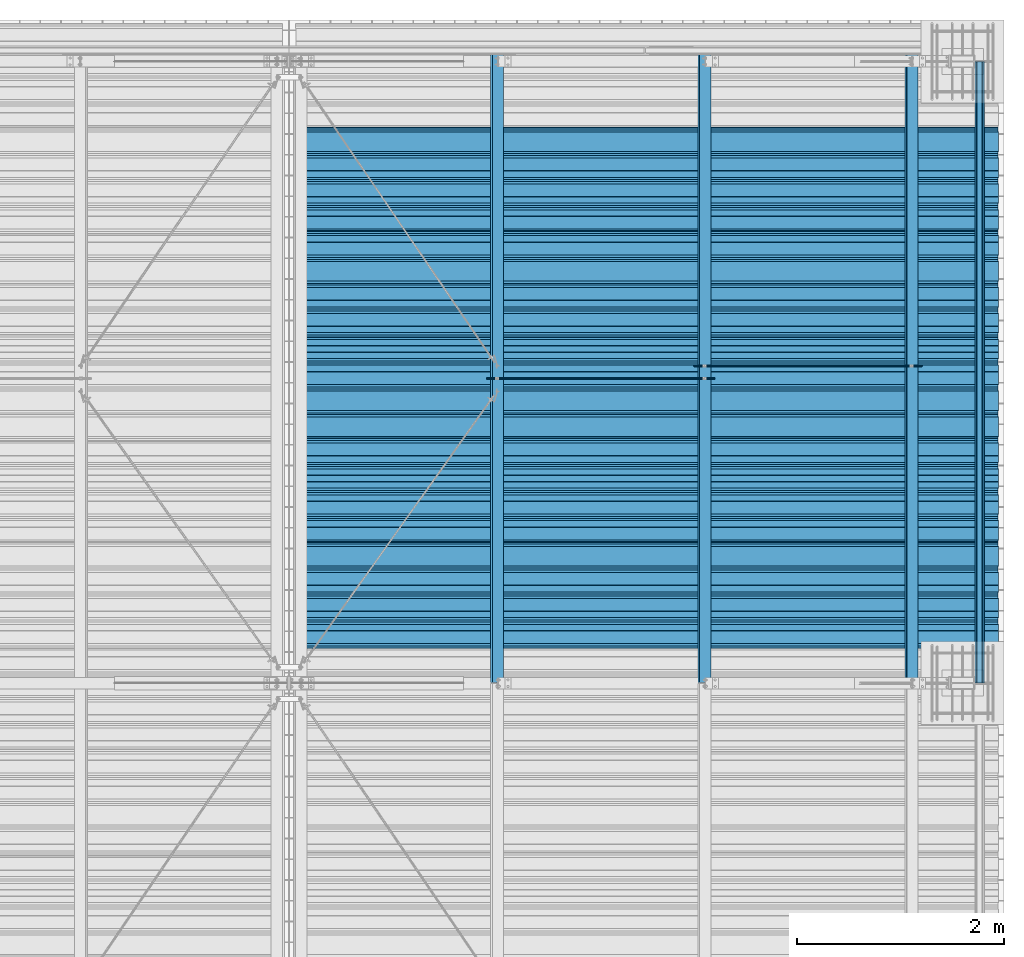
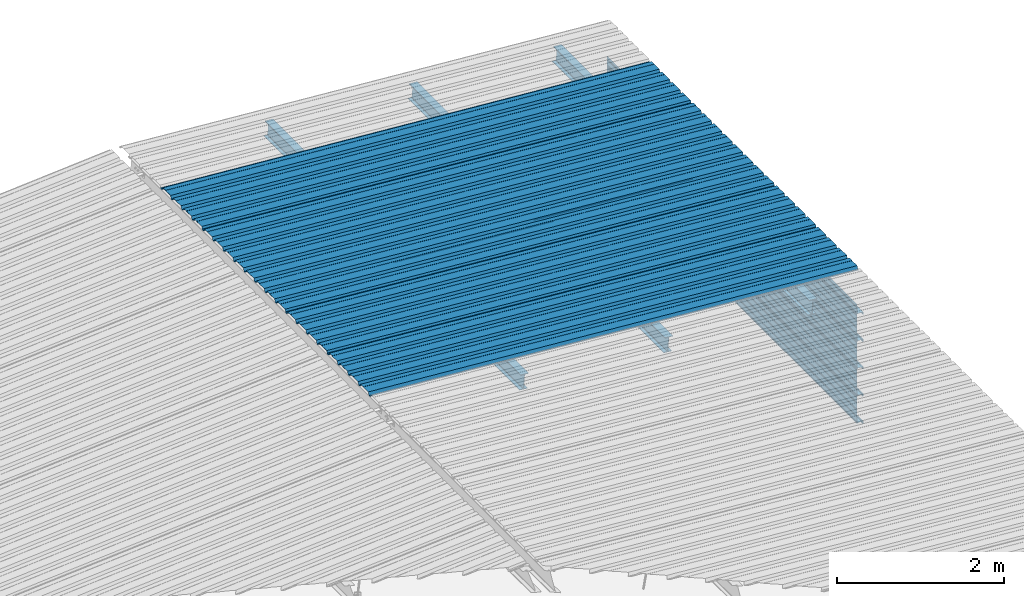
# One storey, part 18 of 70: 15 beams, 15 elements without a shape of their own.
"""IFC2X3 building model written with IfcOpenShell, lengths in millimetres."""

from ifc_helpers import new_model, si_unit, frame, origin_with_axes, origin_2d_with_axis, place, context, subcontext, project, spatial, polyline, circle, i_section, outline, extrude, clip, halfspace, material, type_object, element, aggregate, save


model = new_model("IFC2X3")

# Units and contexts
model_context = context("Model", 3, precision=1e-05, world=origin_with_axes())
body_context = subcontext(model_context, "Body", "Model", "MODEL_VIEW")
ifc_project = project(units=[si_unit("LENGTHUNIT", "METRE", prefix="MILLI"), si_unit("AREAUNIT", "SQUARE_METRE"), si_unit("VOLUMEUNIT", "CUBIC_METRE"), si_unit("MASSUNIT", "GRAM", prefix="KILO"), si_unit("TIMEUNIT", "SECOND"), si_unit("PLANEANGLEUNIT", "RADIAN"), si_unit("SOLIDANGLEUNIT", "STERADIAN"), si_unit("THERMODYNAMICTEMPERATUREUNIT", "DEGREE_CELSIUS"), si_unit("LUMINOUSINTENSITYUNIT", "LUMEN")], contexts=[model_context])

# Site, building, storey
site_placement = place(None, origin_with_axes())
site = spatial("IfcSite", under=ifc_project, at=site_placement, CompositionType="ELEMENT")
building_placement = place(site_placement, origin_with_axes())
building = spatial("IfcBuilding", under=site, at=building_placement, Name="Undefined", CompositionType="ELEMENT")
storey_placement = place(building_placement, origin_with_axes())
storey = spatial("IfcBuildingStorey", under=building, at=storey_placement, Name="Undefined", CompositionType="ELEMENT", Elevation=0.0)

# Assembly, beam
assembly_1_placement = place(storey_placement, origin_with_axes())
assembly_1 = element("IfcElementAssembly", 1, at=assembly_1_placement, inside=storey, Name="Steel Assembly", AssemblyPlace="NOTDEFINED", PredefinedType="RIGID_FRAME")
ifc_material = material(Name="STEEL/S235JR")
beam_type_1 = type_object("IfcBeamType", Name="4.40", PredefinedType="NOTDEFINED")
beam_1_placement = place(assembly_1_placement, frame((6563.60751131961, 18850.0000000002, 5336.31760454404), z_axis=(-0.0766964990376782, 0.0, -0.997054485489817), x_axis=(0.997054485489817, 0.0, -0.0766964990376783)))
beam_1 = element("IfcBeam", 2, at=beam_1_placement, type_object=beam_type_1, material=ifc_material, ObjectType="4.40", context=body_context, shape_type="SweptSolid", body=[
    extrude(outline(polyline([(509.415161132813, 19.5000000011705), (490.584838867188, 19.5000000011705), (468.084838867188, -20.4999999988113), (406.585784912109, -20.4999999988113), (404.585784912109, -18.4999999988122), (345.414215087891, -18.4999999988122), (343.414215087891, -20.4999999988113), (281.915161132813, -20.4999999988113), (259.415161132813, 19.5000000011705), (240.584854125977, 19.5000000011705), (218.084854125977, -20.4999999988113), (156.585784912109, -20.4999999988113), (154.585784912109, -18.4999999988122), (95.4142150878906, -18.4999999988122), (93.4142150878906, -20.4999999988113), (31.9151515960693, -20.4999999988113), (9.41515254974365, 19.5000000011705), (-9.41515254974365, 19.5000000011705), (-31.9151515960693, -20.4999999988113), (-93.4142150878906, -20.4999999988113), (-95.4142150878906, -18.4999999988122), (-154.585784912109, -18.4999999988122), (-156.585784912109, -20.4999999988113), (-218.084854125977, -20.4999999988113), (-240.584854125977, 19.5000000011705), (-259.415161132813, 19.5000000011705), (-281.915161132813, -20.4999999988113), (-343.414215087891, -20.4999999988113), (-345.414215087891, -18.4999999988122), (-404.585784912109, -18.4999999988122), (-406.585784912109, -20.4999999988113), (-468.084838867188, -20.4999999988113), (-490.584838867188, 19.5000000011705), (-509.415161132813, 19.5000000011705), (-516.482360839844, 6.9361057293263), (-517.353942871094, 7.42636680720625), (-510.0, 20.5000000011705), (-490.0, 20.5000000011705), (-467.5, -19.4999999988122), (-407.0, -19.4999999988122), (-405.0, -17.4999999988131), (-345.0, -17.4999999988131), (-343.0, -19.4999999988122), (-282.5, -19.4999999988122), (-260.0, 20.5000000011705), (-240.0, 20.5000000011705), (-217.5, -19.4999999988122), (-157.0, -19.4999999988122), (-155.0, -17.4999999988131), (-95.0, -17.4999999988131), (-93.0, -19.4999999988122), (-32.5, -19.4999999988122), (-10.0, 20.5000000011705), (10.0, 20.5000000011705), (32.5, -19.4999999988122), (93.0, -19.4999999988122), (95.0, -17.4999999988131), (155.0, -17.4999999988131), (157.0, -19.4999999988122), (217.5, -19.4999999988122), (240.0, 20.5000000011705), (260.0, 20.5000000011705), (282.5, -19.4999999988122), (343.0, -19.4999999988122), (345.0, -17.4999999988131), (405.0, -17.4999999988131), (407.0, -19.4999999988122), (467.5, -19.4999999988122), (490.0, 20.5000000011705), (510.0, 20.5000000011705), (517.353942871094, 7.42636680720625), (516.482360839844, 6.9361057293263), (509.415161132813, 19.5000000011705)])), frame((6799.99999999733, 2.8421709430404e-14, 0.0), z_axis=(-1.0, 0.0, 0.0), x_axis=(0.0, -1.0, 0.0)), (0.0, 0.0, 1.0), 6800.0),
])
aggregate(assembly_1, [beam_1])

assembly_2_placement = place(storey_placement, origin_with_axes())
assembly_2 = element("IfcElementAssembly", 3, at=assembly_2_placement, inside=storey, Name="Steel Assembly", AssemblyPlace="NOTDEFINED", PredefinedType="RIGID_FRAME")
beam_2_placement = place(assembly_2_placement, frame((6563.60751131961, 19850.0000000002, 5336.31760454406), z_axis=(-0.0766964990376782, 0.0, -0.997054485489817), x_axis=(0.997054485489817, 0.0, -0.0766964990376783)))
beam_2 = element("IfcBeam", 4, at=beam_2_placement, type_object=beam_type_1, material=ifc_material, ObjectType="4.40", context=body_context, shape_type="SweptSolid", body=[
    extrude(outline(polyline([(509.415161132813, 19.5000000011705), (490.584838867188, 19.5000000011705), (468.084838867188, -20.4999999988113), (406.585784912109, -20.4999999988113), (404.585784912109, -18.4999999988122), (345.414215087891, -18.4999999988122), (343.414215087891, -20.4999999988113), (281.915161132813, -20.4999999988113), (259.415161132813, 19.5000000011705), (240.584854125977, 19.5000000011705), (218.084854125977, -20.4999999988113), (156.585784912109, -20.4999999988113), (154.585784912109, -18.4999999988122), (95.4142150878906, -18.4999999988122), (93.4142150878906, -20.4999999988113), (31.9151515960693, -20.4999999988113), (9.41515254974365, 19.5000000011705), (-9.41515254974365, 19.5000000011705), (-31.9151515960693, -20.4999999988113), (-93.4142150878906, -20.4999999988113), (-95.4142150878906, -18.4999999988122), (-154.585784912109, -18.4999999988122), (-156.585784912109, -20.4999999988113), (-218.084854125977, -20.4999999988113), (-240.584854125977, 19.5000000011705), (-259.415161132813, 19.5000000011705), (-281.915161132813, -20.4999999988113), (-343.414215087891, -20.4999999988113), (-345.414215087891, -18.4999999988122), (-404.585784912109, -18.4999999988122), (-406.585784912109, -20.4999999988113), (-468.084838867188, -20.4999999988113), (-490.584838867188, 19.5000000011705), (-509.415161132813, 19.5000000011705), (-516.482360839844, 6.9361057293263), (-517.353942871094, 7.42636680720625), (-510.0, 20.5000000011705), (-490.0, 20.5000000011705), (-467.5, -19.4999999988122), (-407.0, -19.4999999988122), (-405.0, -17.4999999988131), (-345.0, -17.4999999988131), (-343.0, -19.4999999988122), (-282.5, -19.4999999988122), (-260.0, 20.5000000011705), (-240.0, 20.5000000011705), (-217.5, -19.4999999988122), (-157.0, -19.4999999988122), (-155.0, -17.4999999988131), (-95.0, -17.4999999988131), (-93.0, -19.4999999988122), (-32.5, -19.4999999988122), (-10.0, 20.5000000011705), (10.0, 20.5000000011705), (32.5, -19.4999999988122), (93.0, -19.4999999988122), (95.0, -17.4999999988131), (155.0, -17.4999999988131), (157.0, -19.4999999988122), (217.5, -19.4999999988122), (240.0, 20.5000000011705), (260.0, 20.5000000011705), (282.5, -19.4999999988122), (343.0, -19.4999999988122), (345.0, -17.4999999988131), (405.0, -17.4999999988131), (407.0, -19.4999999988122), (467.5, -19.4999999988122), (490.0, 20.5000000011705), (510.0, 20.5000000011705), (517.353942871094, 7.42636680720625), (516.482360839844, 6.9361057293263), (509.415161132813, 19.5000000011705)])), frame((6799.99999999733, 2.8421709430404e-14, 0.0), z_axis=(-1.0, 0.0, 0.0), x_axis=(0.0, -1.0, 0.0)), (0.0, 0.0, 1.0), 6800.0),
])
aggregate(assembly_2, [beam_2])

assembly_3_placement = place(storey_placement, origin_with_axes())
assembly_3 = element("IfcElementAssembly", 5, at=assembly_3_placement, inside=storey, Name="Steel Assembly", AssemblyPlace="NOTDEFINED", PredefinedType="RIGID_FRAME")
beam_3_placement = place(assembly_3_placement, frame((6563.60751131961, 20850.0000000002, 5336.31760454409), z_axis=(-0.0766964990376782, 0.0, -0.997054485489817), x_axis=(0.997054485489817, 0.0, -0.0766964990376783)))
beam_3 = element("IfcBeam", 6, at=beam_3_placement, type_object=beam_type_1, material=ifc_material, ObjectType="4.40", context=body_context, shape_type="SweptSolid", body=[
    extrude(outline(polyline([(509.415161132813, 19.5000000011705), (490.584838867188, 19.5000000011705), (468.084838867188, -20.4999999988113), (406.585784912109, -20.4999999988113), (404.585784912109, -18.4999999988122), (345.414215087891, -18.4999999988122), (343.414215087891, -20.4999999988113), (281.915161132813, -20.4999999988113), (259.415161132813, 19.5000000011705), (240.584854125977, 19.5000000011705), (218.084854125977, -20.4999999988113), (156.585784912109, -20.4999999988113), (154.585784912109, -18.4999999988122), (95.4142150878906, -18.4999999988122), (93.4142150878906, -20.4999999988113), (31.9151515960693, -20.4999999988113), (9.41515254974365, 19.5000000011705), (-9.41515254974365, 19.5000000011705), (-31.9151515960693, -20.4999999988113), (-93.4142150878906, -20.4999999988113), (-95.4142150878906, -18.4999999988122), (-154.585784912109, -18.4999999988122), (-156.585784912109, -20.4999999988113), (-218.084854125977, -20.4999999988113), (-240.584854125977, 19.5000000011705), (-259.415161132813, 19.5000000011705), (-281.915161132813, -20.4999999988113), (-343.414215087891, -20.4999999988113), (-345.414215087891, -18.4999999988122), (-404.585784912109, -18.4999999988122), (-406.585784912109, -20.4999999988113), (-468.084838867188, -20.4999999988113), (-490.584838867188, 19.5000000011705), (-509.415161132813, 19.5000000011705), (-516.482360839844, 6.9361057293263), (-517.353942871094, 7.42636680720625), (-510.0, 20.5000000011705), (-490.0, 20.5000000011705), (-467.5, -19.4999999988122), (-407.0, -19.4999999988122), (-405.0, -17.4999999988131), (-345.0, -17.4999999988131), (-343.0, -19.4999999988122), (-282.5, -19.4999999988122), (-260.0, 20.5000000011705), (-240.0, 20.5000000011705), (-217.5, -19.4999999988122), (-157.0, -19.4999999988122), (-155.0, -17.4999999988131), (-95.0, -17.4999999988131), (-93.0, -19.4999999988122), (-32.5, -19.4999999988122), (-10.0, 20.5000000011705), (10.0, 20.5000000011705), (32.5, -19.4999999988122), (93.0, -19.4999999988122), (95.0, -17.4999999988131), (155.0, -17.4999999988131), (157.0, -19.4999999988122), (217.5, -19.4999999988122), (240.0, 20.5000000011705), (260.0, 20.5000000011705), (282.5, -19.4999999988122), (343.0, -19.4999999988122), (345.0, -17.4999999988131), (405.0, -17.4999999988131), (407.0, -19.4999999988122), (467.5, -19.4999999988122), (490.0, 20.5000000011705), (510.0, 20.5000000011705), (517.353942871094, 7.42636680720625), (516.482360839844, 6.9361057293263), (509.415161132813, 19.5000000011705)])), frame((6799.99999999733, 2.8421709430404e-14, 0.0), z_axis=(-1.0, 0.0, 0.0), x_axis=(0.0, -1.0, 0.0)), (0.0, 0.0, 1.0), 6800.0),
])
aggregate(assembly_3, [beam_3])

assembly_4_placement = place(storey_placement, origin_with_axes())
assembly_4 = element("IfcElementAssembly", 7, at=assembly_4_placement, inside=storey, Name="Steel Assembly", AssemblyPlace="NOTDEFINED", PredefinedType="RIGID_FRAME")
beam_4_placement = place(assembly_4_placement, frame((6563.60751131961, 21850.0000000002, 5336.31760454412), z_axis=(-0.0766964990376782, 0.0, -0.997054485489817), x_axis=(0.997054485489817, 0.0, -0.0766964990376783)))
beam_4 = element("IfcBeam", 8, at=beam_4_placement, type_object=beam_type_1, material=ifc_material, ObjectType="4.40", context=body_context, shape_type="SweptSolid", body=[
    extrude(outline(polyline([(509.415161132813, 19.5000000011705), (490.584838867188, 19.5000000011705), (468.084838867188, -20.4999999988113), (406.585784912109, -20.4999999988113), (404.585784912109, -18.4999999988122), (345.414215087891, -18.4999999988122), (343.414215087891, -20.4999999988113), (281.915161132813, -20.4999999988113), (259.415161132813, 19.5000000011705), (240.584854125977, 19.5000000011705), (218.084854125977, -20.4999999988113), (156.585784912109, -20.4999999988113), (154.585784912109, -18.4999999988122), (95.4142150878906, -18.4999999988122), (93.4142150878906, -20.4999999988113), (31.9151515960693, -20.4999999988113), (9.41515254974365, 19.5000000011705), (-9.41515254974365, 19.5000000011705), (-31.9151515960693, -20.4999999988113), (-93.4142150878906, -20.4999999988113), (-95.4142150878906, -18.4999999988122), (-154.585784912109, -18.4999999988122), (-156.585784912109, -20.4999999988113), (-218.084854125977, -20.4999999988113), (-240.584854125977, 19.5000000011705), (-259.415161132813, 19.5000000011705), (-281.915161132813, -20.4999999988113), (-343.414215087891, -20.4999999988113), (-345.414215087891, -18.4999999988122), (-404.585784912109, -18.4999999988122), (-406.585784912109, -20.4999999988113), (-468.084838867188, -20.4999999988113), (-490.584838867188, 19.5000000011705), (-509.415161132813, 19.5000000011705), (-516.482360839844, 6.9361057293263), (-517.353942871094, 7.42636680720625), (-510.0, 20.5000000011705), (-490.0, 20.5000000011705), (-467.5, -19.4999999988122), (-407.0, -19.4999999988122), (-405.0, -17.4999999988131), (-345.0, -17.4999999988131), (-343.0, -19.4999999988122), (-282.5, -19.4999999988122), (-260.0, 20.5000000011705), (-240.0, 20.5000000011705), (-217.5, -19.4999999988122), (-157.0, -19.4999999988122), (-155.0, -17.4999999988131), (-95.0, -17.4999999988131), (-93.0, -19.4999999988122), (-32.5, -19.4999999988122), (-10.0, 20.5000000011705), (10.0, 20.5000000011705), (32.5, -19.4999999988122), (93.0, -19.4999999988122), (95.0, -17.4999999988131), (155.0, -17.4999999988131), (157.0, -19.4999999988122), (217.5, -19.4999999988122), (240.0, 20.5000000011705), (260.0, 20.5000000011705), (282.5, -19.4999999988122), (343.0, -19.4999999988122), (345.0, -17.4999999988131), (405.0, -17.4999999988131), (407.0, -19.4999999988122), (467.5, -19.4999999988122), (490.0, 20.5000000011705), (510.0, 20.5000000011705), (517.353942871094, 7.42636680720625), (516.482360839844, 6.9361057293263), (509.415161132813, 19.5000000011705)])), frame((6799.99999999733, 2.8421709430404e-14, 0.0), z_axis=(-1.0, 0.0, 0.0), x_axis=(0.0, -1.0, 0.0)), (0.0, 0.0, 1.0), 6800.0),
])
aggregate(assembly_4, [beam_4])

assembly_5_placement = place(storey_placement, origin_with_axes())
assembly_5 = element("IfcElementAssembly", 9, at=assembly_5_placement, inside=storey, Name="Steel Assembly", AssemblyPlace="NOTDEFINED", PredefinedType="RIGID_FRAME")
beam_5_placement = place(assembly_5_placement, frame((6563.60751131961, 22850.0000000002, 5336.31760454415), z_axis=(-0.0766964990376782, 0.0, -0.997054485489817), x_axis=(0.997054485489817, 0.0, -0.0766964990376783)))
beam_5 = element("IfcBeam", 10, at=beam_5_placement, type_object=beam_type_1, material=ifc_material, ObjectType="4.40", context=body_context, shape_type="SweptSolid", body=[
    extrude(outline(polyline([(509.415161132813, 19.5000000011705), (490.584838867188, 19.5000000011705), (468.084838867188, -20.4999999988113), (406.585784912109, -20.4999999988113), (404.585784912109, -18.4999999988122), (345.414215087891, -18.4999999988122), (343.414215087891, -20.4999999988113), (281.915161132813, -20.4999999988113), (259.415161132813, 19.5000000011705), (240.584854125977, 19.5000000011705), (218.084854125977, -20.4999999988113), (156.585784912109, -20.4999999988113), (154.585784912109, -18.4999999988122), (95.4142150878906, -18.4999999988122), (93.4142150878906, -20.4999999988113), (31.9151515960693, -20.4999999988113), (9.41515254974365, 19.5000000011705), (-9.41515254974365, 19.5000000011705), (-31.9151515960693, -20.4999999988113), (-93.4142150878906, -20.4999999988113), (-95.4142150878906, -18.4999999988122), (-154.585784912109, -18.4999999988122), (-156.585784912109, -20.4999999988113), (-218.084854125977, -20.4999999988113), (-240.584854125977, 19.5000000011705), (-259.415161132813, 19.5000000011705), (-281.915161132813, -20.4999999988113), (-343.414215087891, -20.4999999988113), (-345.414215087891, -18.4999999988122), (-404.585784912109, -18.4999999988122), (-406.585784912109, -20.4999999988113), (-468.084838867188, -20.4999999988113), (-490.584838867188, 19.5000000011705), (-509.415161132813, 19.5000000011705), (-516.482360839844, 6.9361057293263), (-517.353942871094, 7.42636680720625), (-510.0, 20.5000000011705), (-490.0, 20.5000000011705), (-467.5, -19.4999999988122), (-407.0, -19.4999999988122), (-405.0, -17.4999999988131), (-345.0, -17.4999999988131), (-343.0, -19.4999999988122), (-282.5, -19.4999999988122), (-260.0, 20.5000000011705), (-240.0, 20.5000000011705), (-217.5, -19.4999999988122), (-157.0, -19.4999999988122), (-155.0, -17.4999999988131), (-95.0, -17.4999999988131), (-93.0, -19.4999999988122), (-32.5, -19.4999999988122), (-10.0, 20.5000000011705), (10.0, 20.5000000011705), (32.5, -19.4999999988122), (93.0, -19.4999999988122), (95.0, -17.4999999988131), (155.0, -17.4999999988131), (157.0, -19.4999999988122), (217.5, -19.4999999988122), (240.0, 20.5000000011705), (260.0, 20.5000000011705), (282.5, -19.4999999988122), (343.0, -19.4999999988122), (345.0, -17.4999999988131), (405.0, -17.4999999988131), (407.0, -19.4999999988122), (467.5, -19.4999999988122), (490.0, 20.5000000011705), (510.0, 20.5000000011705), (517.353942871094, 7.42636680720625), (516.482360839844, 6.9361057293263), (509.415161132813, 19.5000000011705)])), frame((6799.99999999733, 2.8421709430404e-14, 0.0), z_axis=(-1.0, 0.0, 0.0), x_axis=(0.0, -1.0, 0.0)), (0.0, 0.0, 1.0), 6800.0),
])
aggregate(assembly_5, [beam_5])

assembly_6_placement = place(storey_placement, origin_with_axes())
assembly_6 = element("IfcElementAssembly", 11, at=assembly_6_placement, inside=storey, Name="Steel Assembly", AssemblyPlace="NOTDEFINED", PredefinedType="RIGID_FRAME")
beam_type_2 = type_object("IfcBeamType", Name="400", PredefinedType="NOTDEFINED")
beam_6_placement = place(assembly_6_placement, frame((13165.4999999983, 24000.0, 4618.17396601053), z_axis=(1.0, 0.0, 0.0), x_axis=(0.0, -1.0, 0.0)))
beam_6 = element("IfcBeam", 12, at=beam_6_placement, type_object=beam_type_2, material=ifc_material, ObjectType="400", context=body_context, shape_type="Clipping", body=[
    clip(extrude(outline(polyline([(218.25, -24.994083404541), (214.25, -31.8999996185303), (214.25, -45.5), (199.75, -45.5), (194.25, -42.5), (188.75, -45.5), (124.25, -45.5), (114.25, -41.5), (104.25, -45.5), (24.25, -45.5), (14.25, -41.5), (4.25, -45.5), (-75.75, -45.5), (-85.75, -41.5), (-95.75, -45.5), (-160.25, -45.5), (-165.75, -42.5), (-171.25, -45.5), (-185.75, -45.5), (-185.75, -30.711540222168), (-181.75, -23.8111782073975), (-181.75, 23.311637878418), (-185.75, 30.2119998931885), (-185.75, 44.5), (-217.25, 44.5), (-217.25, 34.7999992370605), (-218.25, 34.7999992370605), (-218.25, 45.5), (-184.75, 45.5), (-184.75, 30.480884552002), (-180.75, 23.5805225372314), (-180.75, -24.0800628662109), (-184.75, -30.9804248809814), (-184.75, -44.5), (-171.504989624023, -44.5), (-165.75, -41.360912322998), (-159.995010375977, -44.5), (-95.9425811767578, -44.5), (-85.75, -40.422966003418), (-75.5574188232422, -44.5), (4.05741739273071, -44.5), (14.25, -40.422966003418), (24.4425830841064, -44.5), (104.057418823242, -44.5), (114.25, -40.422966003418), (124.442581176758, -44.5), (188.495010375977, -44.5), (194.25, -41.360912322998), (200.004989624023, -44.5), (213.25, -44.5), (213.25, -31.6313018798828), (217.25, -24.7253856658936), (217.25, 21.7253856658936), (213.25, 28.6313018798828), (213.25, 42.0), (187.25, 42.0), (187.25, 32.5499992370605), (186.25, 32.5499992370605), (186.25, 43.0), (214.25, 43.0), (214.25, 28.8999996185303), (218.25, 21.994083404541), (218.25, -24.994083404541)])), frame((6000.0, 0.0, 0.0), z_axis=(-1.0, 0.0, 0.0), x_axis=(0.0, -1.0, 0.0)), (0.0, 0.0, 1.0), 6000.0), halfspace(frame((6000.0, 36.6804312648892, -44.9999999999927), z_axis=(0.0, -1.0, 0.0), x_axis=(-1.0, 0.0, 0.0)), False)),
])
aggregate(assembly_6, [beam_6])

assembly_7_placement = place(storey_placement, origin_with_axes())
assembly_7 = element("IfcElementAssembly", 13, at=assembly_7_placement, inside=storey, Name="Steel Assembly", AssemblyPlace="NOTDEFINED", PredefinedType="RIGID_FRAME")
beam_7_placement = place(assembly_7_placement, frame((13165.4999999985, 24000.0, 4218.17396601053), z_axis=(1.0, 0.0, 0.0), x_axis=(0.0, -1.0, 0.0)))
beam_7 = element("IfcBeam", 14, at=beam_7_placement, type_object=beam_type_2, material=ifc_material, ObjectType="400", context=body_context, shape_type="SweptSolid", body=[
    extrude(outline(polyline([(218.25, -24.994083404541), (214.25, -31.8999996185303), (214.25, -45.5), (199.75, -45.5), (194.25, -42.5), (188.75, -45.5), (124.25, -45.5), (114.25, -41.5), (104.25, -45.5), (24.25, -45.5), (14.25, -41.5), (4.25, -45.5), (-75.75, -45.5), (-85.75, -41.5), (-95.75, -45.5), (-160.25, -45.5), (-165.75, -42.5), (-171.25, -45.5), (-185.75, -45.5), (-185.75, -30.711540222168), (-181.75, -23.8111782073975), (-181.75, 23.311637878418), (-185.75, 30.2119998931885), (-185.75, 44.5), (-217.25, 44.5), (-217.25, 34.7999992370605), (-218.25, 34.7999992370605), (-218.25, 45.5), (-184.75, 45.5), (-184.75, 30.480884552002), (-180.75, 23.5805225372314), (-180.75, -24.0800628662109), (-184.75, -30.9804248809814), (-184.75, -44.5), (-171.504989624023, -44.5), (-165.75, -41.360912322998), (-159.995010375977, -44.5), (-95.9425811767578, -44.5), (-85.75, -40.422966003418), (-75.5574188232422, -44.5), (4.05741739273071, -44.5), (14.25, -40.422966003418), (24.4425830841064, -44.5), (104.057418823242, -44.5), (114.25, -40.422966003418), (124.442581176758, -44.5), (188.495010375977, -44.5), (194.25, -41.360912322998), (200.004989624023, -44.5), (213.25, -44.5), (213.25, -31.6313018798828), (217.25, -24.7253856658936), (217.25, 21.7253856658936), (213.25, 28.6313018798828), (213.25, 42.0), (187.25, 42.0), (187.25, 32.5499992370605), (186.25, 32.5499992370605), (186.25, 43.0), (214.25, 43.0), (214.25, 28.8999996185303), (218.25, 21.994083404541), (218.25, -24.994083404541)])), frame((6000.0, 0.0, 0.0), z_axis=(-1.0, 0.0, 0.0), x_axis=(0.0, -1.0, 0.0)), (0.0, 0.0, 1.0), 6000.0),
])
aggregate(assembly_7, [beam_7])

assembly_8_placement = place(storey_placement, origin_with_axes())
assembly_8 = element("IfcElementAssembly", 15, at=assembly_8_placement, inside=storey, Name="Steel Assembly", AssemblyPlace="NOTDEFINED", PredefinedType="RIGID_FRAME")
beam_8_placement = place(assembly_8_placement, frame((13165.4999999986, 24000.0, 3818.17396601053), z_axis=(1.0, 0.0, 0.0), x_axis=(0.0, -1.0, 0.0)))
beam_8 = element("IfcBeam", 16, at=beam_8_placement, type_object=beam_type_2, material=ifc_material, ObjectType="400", context=body_context, shape_type="SweptSolid", body=[
    extrude(outline(polyline([(218.25, -24.994083404541), (214.25, -31.8999996185303), (214.25, -45.5), (199.75, -45.5), (194.25, -42.5), (188.75, -45.5), (124.25, -45.5), (114.25, -41.5), (104.25, -45.5), (24.25, -45.5), (14.25, -41.5), (4.25, -45.5), (-75.75, -45.5), (-85.75, -41.5), (-95.75, -45.5), (-160.25, -45.5), (-165.75, -42.5), (-171.25, -45.5), (-185.75, -45.5), (-185.75, -30.711540222168), (-181.75, -23.8111782073975), (-181.75, 23.311637878418), (-185.75, 30.2119998931885), (-185.75, 44.5), (-217.25, 44.5), (-217.25, 34.7999992370605), (-218.25, 34.7999992370605), (-218.25, 45.5), (-184.75, 45.5), (-184.75, 30.480884552002), (-180.75, 23.5805225372314), (-180.75, -24.0800628662109), (-184.75, -30.9804248809814), (-184.75, -44.5), (-171.504989624023, -44.5), (-165.75, -41.360912322998), (-159.995010375977, -44.5), (-95.9425811767578, -44.5), (-85.75, -40.422966003418), (-75.5574188232422, -44.5), (4.05741739273071, -44.5), (14.25, -40.422966003418), (24.4425830841064, -44.5), (104.057418823242, -44.5), (114.25, -40.422966003418), (124.442581176758, -44.5), (188.495010375977, -44.5), (194.25, -41.360912322998), (200.004989624023, -44.5), (213.25, -44.5), (213.25, -31.6313018798828), (217.25, -24.7253856658936), (217.25, 21.7253856658936), (213.25, 28.6313018798828), (213.25, 42.0), (187.25, 42.0), (187.25, 32.5499992370605), (186.25, 32.5499992370605), (186.25, 43.0), (214.25, 43.0), (214.25, 28.8999996185303), (218.25, 21.994083404541), (218.25, -24.994083404541)])), frame((6000.0, 0.0, 0.0), z_axis=(-1.0, 0.0, 0.0), x_axis=(0.0, -1.0, 0.0)), (0.0, 0.0, 1.0), 6000.0),
])
aggregate(assembly_8, [beam_8])

assembly_9_placement = place(storey_placement, origin_with_axes())
assembly_9 = element("IfcElementAssembly", 17, at=assembly_9_placement, inside=storey, Name="Steel Assembly", AssemblyPlace="NOTDEFINED", PredefinedType="RIGID_FRAME")
beam_9_placement = place(assembly_9_placement, frame((13165.4999999988, 24000.0, 3418.17396601053), z_axis=(1.0, 0.0, 0.0), x_axis=(0.0, -1.0, 0.0)))
beam_9 = element("IfcBeam", 18, at=beam_9_placement, type_object=beam_type_2, material=ifc_material, ObjectType="400", context=body_context, shape_type="SweptSolid", body=[
    extrude(outline(polyline([(218.25, -24.994083404541), (214.25, -31.8999996185303), (214.25, -45.5), (199.75, -45.5), (194.25, -42.5), (188.75, -45.5), (124.25, -45.5), (114.25, -41.5), (104.25, -45.5), (24.25, -45.5), (14.25, -41.5), (4.25, -45.5), (-75.75, -45.5), (-85.75, -41.5), (-95.75, -45.5), (-160.25, -45.5), (-165.75, -42.5), (-171.25, -45.5), (-185.75, -45.5), (-185.75, -30.711540222168), (-181.75, -23.8111782073975), (-181.75, 23.311637878418), (-185.75, 30.2119998931885), (-185.75, 44.5), (-217.25, 44.5), (-217.25, 34.7999992370605), (-218.25, 34.7999992370605), (-218.25, 45.5), (-184.75, 45.5), (-184.75, 30.480884552002), (-180.75, 23.5805225372314), (-180.75, -24.0800628662109), (-184.75, -30.9804248809814), (-184.75, -44.5), (-171.504989624023, -44.5), (-165.75, -41.360912322998), (-159.995010375977, -44.5), (-95.9425811767578, -44.5), (-85.75, -40.422966003418), (-75.5574188232422, -44.5), (4.05741739273071, -44.5), (14.25, -40.422966003418), (24.4425830841064, -44.5), (104.057418823242, -44.5), (114.25, -40.422966003418), (124.442581176758, -44.5), (188.495010375977, -44.5), (194.25, -41.360912322998), (200.004989624023, -44.5), (213.25, -44.5), (213.25, -31.6313018798828), (217.25, -24.7253856658936), (217.25, 21.7253856658936), (213.25, 28.6313018798828), (213.25, 42.0), (187.25, 42.0), (187.25, 32.5499992370605), (186.25, 32.5499992370605), (186.25, 43.0), (214.25, 43.0), (214.25, 28.8999996185303), (218.25, 21.994083404541), (218.25, -24.994083404541)])), frame((6000.0, 0.0, 0.0), z_axis=(-1.0, 0.0, 0.0), x_axis=(0.0, -1.0, 0.0)), (0.0, 0.0, 1.0), 6000.0),
])
aggregate(assembly_9, [beam_9])

assembly_10_placement = place(storey_placement, origin_with_axes())
assembly_10 = element("IfcElementAssembly", 19, at=assembly_10_placement, inside=storey, Name="Steel Assembly", AssemblyPlace="NOTDEFINED", PredefinedType="RIGID_FRAME")
beam_10_placement = place(assembly_10_placement, frame((13165.4999999989, 24000.0, 3018.17396601053), z_axis=(1.0, 0.0, 0.0), x_axis=(0.0, -1.0, 0.0)))
beam_10 = element("IfcBeam", 20, at=beam_10_placement, type_object=beam_type_2, material=ifc_material, ObjectType="400", context=body_context, shape_type="SweptSolid", body=[
    extrude(outline(polyline([(218.25, -24.994083404541), (214.25, -31.8999996185303), (214.25, -45.5), (199.75, -45.5), (194.25, -42.5), (188.75, -45.5), (124.25, -45.5), (114.25, -41.5), (104.25, -45.5), (24.25, -45.5), (14.25, -41.5), (4.25, -45.5), (-75.75, -45.5), (-85.75, -41.5), (-95.75, -45.5), (-160.25, -45.5), (-165.75, -42.5), (-171.25, -45.5), (-185.75, -45.5), (-185.75, -30.711540222168), (-181.75, -23.8111782073975), (-181.75, 23.311637878418), (-185.75, 30.2119998931885), (-185.75, 44.5), (-217.25, 44.5), (-217.25, 34.7999992370605), (-218.25, 34.7999992370605), (-218.25, 45.5), (-184.75, 45.5), (-184.75, 30.480884552002), (-180.75, 23.5805225372314), (-180.75, -24.0800628662109), (-184.75, -30.9804248809814), (-184.75, -44.5), (-171.504989624023, -44.5), (-165.75, -41.360912322998), (-159.995010375977, -44.5), (-95.9425811767578, -44.5), (-85.75, -40.422966003418), (-75.5574188232422, -44.5), (4.05741739273071, -44.5), (14.25, -40.422966003418), (24.4425830841064, -44.5), (104.057418823242, -44.5), (114.25, -40.422966003418), (124.442581176758, -44.5), (188.495010375977, -44.5), (194.25, -41.360912322998), (200.004989624023, -44.5), (213.25, -44.5), (213.25, -31.6313018798828), (217.25, -24.7253856658936), (217.25, 21.7253856658936), (213.25, 28.6313018798828), (213.25, 42.0), (187.25, 42.0), (187.25, 32.5499992370605), (186.25, 32.5499992370605), (186.25, 43.0), (214.25, 43.0), (214.25, 28.8999996185303), (218.25, 21.994083404541), (218.25, -24.994083404541)])), frame((6000.0, 0.0, 0.0), z_axis=(-1.0, 0.0, 0.0), x_axis=(0.0, -1.0, 0.0)), (0.0, 0.0, 1.0), 6000.0),
])
aggregate(assembly_10, [beam_10])

assembly_11_placement = place(storey_placement, origin_with_axes())
assembly_11 = element("IfcElementAssembly", 21, at=assembly_11_placement, inside=storey, Name="Steel Assembly", AssemblyPlace="NOTDEFINED", PredefinedType="RIGID_FRAME")
beam_type_3 = type_object("IfcBeamType", Name="D14", PredefinedType="NOTDEFINED")
beam_11_placement = place(assembly_11_placement, frame((10408.7311663468, 21060.0000000001, 4909.65333500212), z_axis=(-0.0766964990376782, 0.0, -0.997054485489817), x_axis=(0.997054485489817, 0.0, -0.0766964990376783)))
beam_11 = element("IfcBeam", 22, at=beam_11_placement, type_object=beam_type_3, material=ifc_material, Name="THREAD60MM", ObjectType="D14", context=body_context, shape_type="SweptSolid", body=[
    extrude(circle(Radius=7.0, at=origin_2d_with_axis()), frame((2205.90843239298, 9.09494701772928e-13, -9.40107830921147e-13), z_axis=(-1.0, 0.0, 0.0), x_axis=(0.0, -1.0, 0.0)), (0.0, 0.0, 1.0), 2205.91),
])
aggregate(assembly_11, [beam_11])

assembly_12_placement = place(storey_placement, origin_with_axes())
assembly_12 = element("IfcElementAssembly", 23, at=assembly_12_placement, inside=storey, Name="Steel Assembly", AssemblyPlace="NOTDEFINED", PredefinedType="RIGID_FRAME")
beam_12_placement = place(assembly_12_placement, frame((8408.73116634676, 20940.0000000001, 5063.49948915789), z_axis=(-0.0766964990376782, 0.0, -0.997054485489817), x_axis=(0.997054485489817, 0.0, -0.0766964990376783)))
beam_12 = element("IfcBeam", 24, at=beam_12_placement, type_object=beam_type_3, material=ifc_material, Name="THREAD60MM", ObjectType="D14", context=body_context, shape_type="SweptSolid", body=[
    extrude(circle(Radius=7.0, at=origin_2d_with_axis()), frame((2205.90843239298, 9.09494701772928e-13, -9.40107830921147e-13), z_axis=(-1.0, 0.0, 0.0), x_axis=(0.0, -1.0, 0.0)), (0.0, 0.0, 1.0), 2205.91),
])
aggregate(assembly_12, [beam_12])

assembly_13_placement = place(storey_placement, origin_with_axes())
assembly_13 = element("IfcElementAssembly", 25, at=assembly_13_placement, inside=storey, Name="Steel Assembly", AssemblyPlace="NOTDEFINED", PredefinedType="RIGID_FRAME")
beam_type_4 = type_object("IfcBeamType", Name="IPE220", PredefinedType="NOTDEFINED")
beam_13_placement = place(assembly_13_placement, frame((12508.4366148951, 18000.0, 4748.13753093754), z_axis=(0.0766964990376782, 0.0, 0.997054485489817), x_axis=(0.0, 1.0, 0.0)))
beam_13 = element("IfcBeam", 26, at=beam_13_placement, type_object=beam_type_4, material=ifc_material, ObjectType="IPE220", context=body_context, shape_type="Clipping", body=[
    clip(extrude(i_section(OverallWidth=110.0, OverallDepth=220.0, WebThickness=5.900000095, FlangeThickness=9.199999809, FilletRadius=12.0, at=origin_2d_with_axis()), frame((6150.0000000001, 0.0, 0.0), z_axis=(-1.0, 0.0, 0.0), x_axis=(0.0, -1.0, 0.0)), (0.0, 0.0, 1.0), 6145.0), halfspace(frame((4.99999999999636, 7.09405867382884e-11, -1.79170456249267e-10), z_axis=(1.0, 0.0, 0.0), x_axis=(0.0, -1.0, 0.0)), True)),
])
aggregate(assembly_13, [beam_13])

assembly_14_placement = place(storey_placement, origin_with_axes())
assembly_14 = element("IfcElementAssembly", 27, at=assembly_14_placement, inside=storey, Name="Steel Assembly", AssemblyPlace="NOTDEFINED", PredefinedType="RIGID_FRAME")
beam_14_placement = place(assembly_14_placement, frame((10508.4366148951, 18000.0, 4901.98368509286), z_axis=(0.0766964990376782, 0.0, 0.997054485489817), x_axis=(0.0, 1.0, 0.0)))
beam_14 = element("IfcBeam", 28, at=beam_14_placement, type_object=beam_type_4, material=ifc_material, ObjectType="IPE220", context=body_context, shape_type="Clipping", body=[
    clip(extrude(i_section(OverallWidth=110.0, OverallDepth=220.0, WebThickness=5.900000095, FlangeThickness=9.199999809, FilletRadius=12.0, at=origin_2d_with_axis()), frame((6150.0000000001, 0.0, 0.0), z_axis=(-1.0, 0.0, 0.0), x_axis=(0.0, -1.0, 0.0)), (0.0, 0.0, 1.0), 6145.0), halfspace(frame((4.99999999999636, 7.09405867382884e-11, -1.79170456249267e-10), z_axis=(1.0, 0.0, 0.0), x_axis=(0.0, -1.0, 0.0)), True)),
])
aggregate(assembly_14, [beam_14])

assembly_15_placement = place(storey_placement, origin_with_axes())
assembly_15 = element("IfcElementAssembly", 29, at=assembly_15_placement, inside=storey, Name="Steel Assembly", AssemblyPlace="NOTDEFINED", PredefinedType="RIGID_FRAME")
beam_15_placement = place(assembly_15_placement, frame((8508.43661489513, 18000.0, 5055.82983924862), z_axis=(0.0766964990376782, 0.0, 0.997054485489817), x_axis=(0.0, 1.0, 0.0)))
beam_15 = element("IfcBeam", 30, at=beam_15_placement, type_object=beam_type_4, material=ifc_material, ObjectType="IPE220", context=body_context, shape_type="Clipping", body=[
    clip(extrude(i_section(OverallWidth=110.0, OverallDepth=220.0, WebThickness=5.900000095, FlangeThickness=9.199999809, FilletRadius=12.0, at=origin_2d_with_axis()), frame((6150.0000000001, 0.0, 0.0), z_axis=(-1.0, 0.0, 0.0), x_axis=(0.0, -1.0, 0.0)), (0.0, 0.0, 1.0), 6145.0), halfspace(frame((4.99999999999636, 7.09405867382884e-11, -1.79170456249267e-10), z_axis=(1.0, 0.0, 0.0), x_axis=(0.0, -1.0, 0.0)), True)),
])
aggregate(assembly_15, [beam_15])

save(model, "model.ifc")
